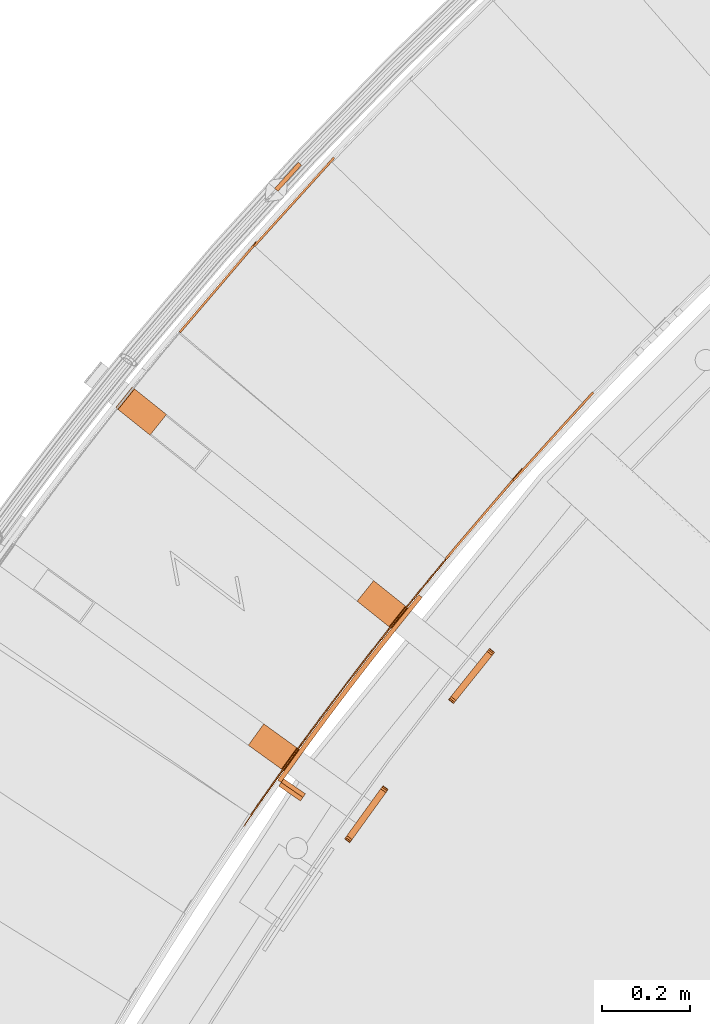
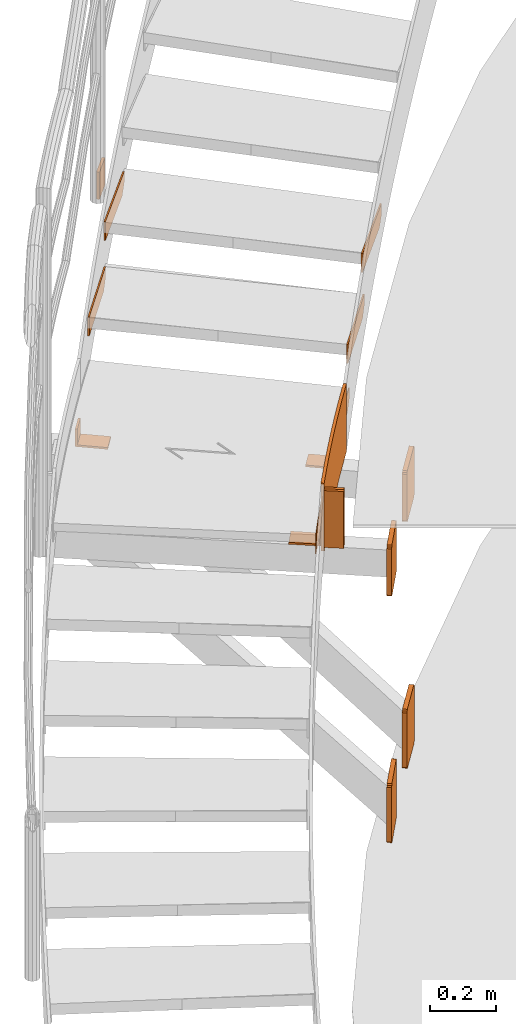
# One storey, part 68 of 126: 16 proxies.
"""IFC2X3 building model written with IfcOpenShell, lengths in millimetres."""

from ifc_helpers import new_model, si_unit, origin, origin_with_axes, place, context, project, spatial, faceted_brep, material, element, save


model = new_model("IFC2X3")

# Units and contexts
context_of_model_1 = context(None, 3, precision=0.1, world=origin())
context_of_model_2 = context(None, 3, precision=0.1, world=origin())
ifc_project = project(units=[si_unit("LENGTHUNIT", "METRE", prefix="MILLI"), si_unit("AREAUNIT", "SQUARE_METRE", prefix="CENTI"), si_unit("VOLUMEUNIT", "CUBIC_METRE", prefix="CENTI"), si_unit("MASSUNIT", "GRAM", prefix="KILO")], contexts=[context_of_model_1, context_of_model_2])

# Site, building, storey
site_placement = place(None, origin_with_axes())
site = spatial("IfcSite", under=ifc_project, at=site_placement, CompositionType="ELEMENT")
building_placement = place(site_placement, origin_with_axes())
building = spatial("IfcBuilding", under=site, at=building_placement, CompositionType="ELEMENT")
storey_placement = place(building_placement, origin_with_axes())
storey = spatial("IfcBuildingStorey", under=building, at=storey_placement, CompositionType="ELEMENT")

# Proxies
ifc_material = material(Name="S235JRG2")
proxy_1_placement = place(storey_placement, origin_with_axes())
element("IfcBuildingElementProxy", 1, at=proxy_1_placement, inside=storey, material=ifc_material, context=context_of_model_2, shape_type="Brep", body=[
    faceted_brep([(1853.9676, 13154.518, 8417.11), (1857.7719, 13151.274, 8417.11), (1857.7719, 13151.274, 8487.11), (1853.9676, 13154.518, 8487.11), (2029.1751, 13359.95, 8487.11), (2032.9794, 13356.706, 8487.11), (2032.9794, 13356.706, 8447.11), (2029.1751, 13359.95, 8447.11), (2009.7076, 13337.125, 8417.11), (2013.5119, 13333.88, 8417.11)], [[[0, 1, 2, 3]], [[4, 5, 6, 7]], [[0, 8, 9, 1]], [[1, 9, 6, 5, 2]], [[2, 5, 4, 3]], [[0, 3, 4, 7, 8]], [[6, 9, 8, 7]]]),
])
proxy_2_placement = place(storey_placement, origin_with_axes())
element("IfcBuildingElementProxy", 2, at=proxy_2_placement, inside=storey, material=ifc_material, context=context_of_model_2, shape_type="Brep", body=[
    faceted_brep([(1249.0844, 13670.407, 8417.11), (1252.8887, 13667.163, 8417.11), (1252.8887, 13667.163, 8487.11), (1249.0844, 13670.407, 8487.11), (1424.292, 13875.839, 8487.11), (1428.0963, 13872.595, 8487.11), (1428.0963, 13872.595, 8447.11), (1424.292, 13875.839, 8447.11), (1404.8245, 13853.013, 8417.11), (1408.6288, 13849.769, 8417.11)], [[[0, 1, 2, 3]], [[4, 5, 6, 7]], [[0, 8, 9, 1]], [[1, 9, 6, 5, 2]], [[2, 5, 4, 3]], [[0, 3, 4, 7, 8]], [[6, 9, 8, 7]]]),
])
proxy_3_placement = place(storey_placement, origin_with_axes())
element("IfcBuildingElementProxy", 3, at=proxy_3_placement, inside=storey, material=ifc_material, context=context_of_model_2, shape_type="Brep", body=[
    faceted_brep([(2008.201, 13333.334, 8590.27), (2011.9082, 13329.979, 8590.27), (2011.9082, 13329.979, 8660.27), (2008.201, 13333.334, 8660.27), (2189.3793, 13533.52, 8660.27), (2193.0864, 13530.165, 8660.27), (2193.0864, 13530.165, 8620.27), (2189.3793, 13533.52, 8620.27), (2169.2483, 13511.277, 8590.27), (2172.9555, 13507.922, 8590.27)], [[[0, 1, 2, 3]], [[4, 5, 6, 7]], [[0, 8, 9, 1]], [[1, 9, 6, 5, 2]], [[2, 5, 4, 3]], [[0, 3, 4, 7, 8]], [[6, 9, 8, 7]]]),
])
proxy_4_placement = place(storey_placement, origin_with_axes())
element("IfcBuildingElementProxy", 4, at=proxy_4_placement, inside=storey, material=ifc_material, context=context_of_model_2, shape_type="Brep", body=[
    faceted_brep([(1418.7644, 13866.803, 8590.27), (1422.4715, 13863.448, 8590.27), (1422.4715, 13863.448, 8660.27), (1418.7644, 13866.803, 8660.27), (1599.9426, 14066.989, 8660.27), (1603.6497, 14063.634, 8660.27), (1603.6497, 14063.634, 8620.27), (1599.9426, 14066.989, 8620.27), (1579.8117, 14044.746, 8590.27), (1583.5188, 14041.391, 8590.27)], [[[0, 1, 2, 3]], [[4, 5, 6, 7]], [[0, 8, 9, 1]], [[1, 9, 6, 5, 2]], [[2, 5, 4, 3]], [[0, 3, 4, 7, 8]], [[6, 9, 8, 7]]]),
])
proxy_5_placement = place(storey_placement, origin_with_axes())
element("IfcBuildingElementProxy", 5, at=proxy_5_placement, inside=storey, material=ifc_material, context=context_of_model_2, shape_type="Brep", body=[
    faceted_brep([(1479.0371, 12658.206, 8163.85), (1487.1793, 12652.4, 8163.85), (1481.7231, 12644.691, 8163.85), (1473.4801, 12650.355, 8163.85), (1487.1793, 12652.4, 8413.85), (1481.7231, 12644.691, 8413.85), (1479.0371, 12658.206, 8413.85), (1473.4801, 12650.355, 8413.85), (1511.6812, 12703.652, 8163.85), (1519.7827, 12697.79, 8163.85), (1519.7827, 12697.79, 8413.85), (1511.6812, 12703.652, 8413.85), (1544.6417, 12748.87, 8163.85), (1552.7021, 12742.951, 8163.85), (1552.7021, 12742.951, 8413.85), (1544.6417, 12748.87, 8413.85), (1577.9169, 12793.856, 8163.85), (1585.9358, 12787.881, 8163.85), (1585.9358, 12787.881, 8413.85), (1577.9169, 12793.856, 8413.85), (1611.5053, 12838.609, 8163.85), (1619.4824, 12832.578, 8163.85), (1619.4824, 12832.578, 8413.85), (1611.5053, 12838.609, 8413.85), (1645.4053, 12883.126, 8163.85), (1653.34, 12877.04, 8163.85), (1653.34, 12877.04, 8413.85), (1645.4053, 12883.126, 8413.85), (1679.6152, 12927.406, 8163.85), (1687.5072, 12921.264, 8163.85), (1687.5072, 12921.264, 8413.85), (1679.6152, 12927.406, 8413.85), (1714.1332, 12971.445, 8163.85), (1721.9822, 12965.249, 8163.85), (1721.9822, 12965.249, 8413.85), (1714.1332, 12971.445, 8413.85), (1748.9578, 13015.243, 8163.85), (1756.7634, 13008.992, 8163.85), (1756.7634, 13008.992, 8413.85), (1748.9578, 13015.243, 8413.85), (1784.0873, 13058.797, 8163.85), (1791.849, 13052.492, 8163.85), (1791.849, 13052.492, 8413.85), (1784.0873, 13058.797, 8413.85), (1794.2648, 13071.236, 8163.85), (1802.5361, 13065.554, 8163.85), (1802.5361, 13065.554, 8413.85), (1794.2648, 13071.236, 8413.85)], [[[0, 1, 2, 3]], [[1, 4, 5, 2]], [[4, 6, 7, 5]], [[0, 3, 7, 6]], [[0, 8, 9, 1]], [[1, 9, 10, 4]], [[4, 10, 11, 6]], [[6, 11, 8, 0]], [[8, 12, 13, 9]], [[9, 13, 14, 10]], [[10, 14, 15, 11]], [[11, 15, 12, 8]], [[12, 16, 17, 13]], [[13, 17, 18, 14]], [[14, 18, 19, 15]], [[15, 19, 16, 12]], [[16, 20, 21, 17]], [[17, 21, 22, 18]], [[18, 22, 23, 19]], [[19, 23, 20, 16]], [[20, 24, 25, 21]], [[21, 25, 26, 22]], [[22, 26, 27, 23]], [[23, 27, 24, 20]], [[24, 28, 29, 25]], [[25, 29, 30, 26]], [[26, 30, 31, 27]], [[27, 31, 28, 24]], [[28, 32, 33, 29]], [[29, 33, 34, 30]], [[30, 34, 35, 31]], [[31, 35, 32, 28]], [[32, 36, 37, 33]], [[33, 37, 38, 34]], [[34, 38, 39, 35]], [[35, 39, 36, 32]], [[36, 40, 41, 37]], [[37, 41, 42, 38]], [[38, 42, 43, 39]], [[39, 43, 40, 36]], [[40, 44, 45, 41]], [[41, 45, 46, 42]], [[42, 46, 47, 43]], [[40, 43, 47, 44]], [[2, 5, 7, 3]], [[44, 47, 46, 45]]]),
])
proxy_6_placement = place(storey_placement, origin_with_axes())
element("IfcBuildingElementProxy", 6, at=proxy_6_placement, inside=storey, material=ifc_material, context=context_of_model_2, shape_type="Brep", body=[
    faceted_brep([(1105.1728, 13497.322, 8228.85), (1142.6996, 13544.138, 8228.85), (1142.6996, 13544.138, 8163.85), (1105.1728, 13497.322, 8163.85), (1110.6347, 13492.944, 8228.85), (1148.1615, 13539.76, 8228.85), (1110.6347, 13492.944, 8170.85), (1148.1615, 13539.76, 8170.85), (1183.1995, 13434.777, 8170.85), (1220.7263, 13481.593, 8170.85), (1183.1995, 13434.777, 8163.85), (1220.7263, 13481.593, 8163.85)], [[[0, 1, 2, 3]], [[0, 4, 5, 1]], [[4, 6, 7, 5]], [[6, 8, 9, 7]], [[8, 10, 11, 9]], [[3, 2, 11, 10]], [[3, 10, 8, 6, 4, 0]], [[1, 5, 7, 9, 11, 2]]]),
])
proxy_7_placement = place(storey_placement, origin_with_axes())
element("IfcBuildingElementProxy", 7, at=proxy_7_placement, inside=storey, material=ifc_material, context=context_of_model_2, shape_type="Brep", body=[
    faceted_brep([(1958.0072, 12929.051, 8018.85), (1961.5974, 12933.53, 8019.9918), (1964.6411, 12937.327, 8023.2434), (1966.6748, 12939.864, 8028.1098), (1967.3889, 12940.755, 8033.85), (1967.3889, 12940.755, 8193.85), (1966.6748, 12939.864, 8199.5903), (1964.6411, 12937.327, 8204.4566), (1961.5974, 12933.53, 8207.7082), (1958.0072, 12929.051, 8208.85), (1882.9536, 12835.419, 8208.85), (1879.3633, 12830.94, 8207.7082), (1876.3197, 12827.143, 8204.4566), (1874.286, 12824.606, 8199.5903), (1873.5719, 12823.715, 8193.85), (1873.5719, 12823.715, 8033.85), (1874.286, 12824.606, 8028.1098), (1876.3197, 12827.143, 8023.2434), (1879.3633, 12830.94, 8019.9918), (1882.9536, 12835.419, 8018.85), (1946.3032, 12938.433, 8018.85), (1871.2496, 12844.801, 8018.85), (1867.6593, 12840.322, 8019.9918), (1864.6157, 12836.525, 8023.2434), (1862.582, 12833.988, 8028.1098), (1861.8679, 12833.097, 8033.85), (1861.8679, 12833.097, 8193.85), (1862.582, 12833.988, 8199.5903), (1864.6157, 12836.525, 8204.4566), (1867.6593, 12840.322, 8207.7082), (1871.2496, 12844.801, 8208.85), (1946.3032, 12938.433, 8208.85), (1949.8934, 12942.912, 8207.7082), (1952.9371, 12946.709, 8204.4566), (1954.9708, 12949.246, 8199.5903), (1955.6849, 12950.137, 8193.85), (1955.6849, 12950.137, 8033.85), (1954.9708, 12949.246, 8028.1098), (1952.9371, 12946.709, 8023.2434), (1949.8934, 12942.912, 8019.9918)], [[[0, 1, 2, 3, 4, 5, 6, 7, 8, 9, 10, 11, 12, 13, 14, 15, 16, 17, 18, 19]], [[20, 21, 22, 23, 24, 25, 26, 27, 28, 29, 30, 31, 32, 33, 34, 35, 36, 37, 38, 39]], [[0, 20, 39, 1]], [[1, 39, 38, 2]], [[2, 38, 37, 3]], [[3, 37, 36, 4]], [[4, 36, 35, 5]], [[5, 35, 34, 6]], [[6, 34, 33, 7]], [[7, 33, 32, 8]], [[8, 32, 31, 9]], [[9, 31, 30, 10]], [[10, 30, 29, 11]], [[11, 29, 28, 12]], [[12, 28, 27, 13]], [[13, 27, 26, 14]], [[14, 26, 25, 15]], [[15, 25, 24, 16]], [[16, 24, 23, 17]], [[17, 23, 22, 18]], [[18, 22, 21, 19]], [[19, 21, 20, 0]]]),
])
proxy_8_placement = place(storey_placement, origin_with_axes())
element("IfcBuildingElementProxy", 8, at=proxy_8_placement, inside=storey, material=ifc_material, context=context_of_model_2, shape_type="Brep", body=[
    faceted_brep([(1958.0073, 12929.051, 7109.1772), (1961.5975, 12933.53, 7110.319), (1964.6411, 12937.327, 7113.5706), (1966.6748, 12939.864, 7118.4369), (1967.389, 12940.755, 7124.1772), (1967.389, 12940.755, 7314.1772), (1966.6748, 12939.864, 7319.9174), (1964.6411, 12937.327, 7324.7838), (1961.5975, 12933.53, 7328.0354), (1958.0073, 12929.051, 7329.1772), (1882.9536, 12835.419, 7329.1772), (1879.3634, 12830.94, 7328.0354), (1876.3198, 12827.143, 7324.7838), (1874.2861, 12824.606, 7319.9174), (1873.5719, 12823.715, 7314.1772), (1873.5719, 12823.715, 7124.1772), (1874.2861, 12824.606, 7118.4369), (1876.3198, 12827.143, 7113.5706), (1879.3634, 12830.94, 7110.319), (1882.9536, 12835.419, 7109.1772), (1946.3033, 12938.433, 7109.1772), (1871.2496, 12844.801, 7109.1772), (1867.6594, 12840.322, 7110.319), (1864.6158, 12836.525, 7113.5706), (1862.5821, 12833.988, 7118.4369), (1861.8679, 12833.097, 7124.1772), (1861.8679, 12833.097, 7314.1772), (1862.5821, 12833.988, 7319.9174), (1864.6158, 12836.525, 7324.7838), (1867.6594, 12840.322, 7328.0354), (1871.2496, 12844.801, 7329.1772), (1946.3033, 12938.433, 7329.1772), (1949.8935, 12942.912, 7328.0354), (1952.9371, 12946.709, 7324.7838), (1954.9708, 12949.246, 7319.9174), (1955.685, 12950.137, 7314.1772), (1955.685, 12950.137, 7124.1772), (1954.9708, 12949.246, 7118.4369), (1952.9371, 12946.709, 7113.5706), (1949.8935, 12942.912, 7110.319)], [[[0, 1, 2, 3, 4, 5, 6, 7, 8, 9, 10, 11, 12, 13, 14, 15, 16, 17, 18, 19]], [[20, 21, 22, 23, 24, 25, 26, 27, 28, 29, 30, 31, 32, 33, 34, 35, 36, 37, 38, 39]], [[0, 20, 39, 1]], [[1, 39, 38, 2]], [[2, 38, 37, 3]], [[3, 37, 36, 4]], [[4, 36, 35, 5]], [[5, 35, 34, 6]], [[6, 34, 33, 7]], [[7, 33, 32, 8]], [[8, 32, 31, 9]], [[9, 31, 30, 10]], [[10, 30, 29, 11]], [[11, 29, 28, 12]], [[12, 28, 27, 13]], [[13, 27, 26, 14]], [[14, 26, 25, 15]], [[15, 25, 24, 16]], [[16, 24, 23, 17]], [[17, 23, 22, 18]], [[18, 22, 21, 19]], [[19, 21, 20, 0]]]),
])
proxy_9_placement = place(storey_placement, origin_with_axes())
element("IfcBuildingElementProxy", 9, at=proxy_9_placement, inside=storey, material=ifc_material, context=context_of_model_2, shape_type="Brep", body=[
    faceted_brep([(1394.7133, 12546.422, 8243.85), (1397.1859, 12544.723, 8243.85), (1397.1859, 12544.723, 8313.85), (1394.7133, 12546.422, 8313.85), (1399.1426, 12552.869, 8243.85), (1401.6136, 12551.167, 8243.85), (1401.6136, 12551.167, 8313.85), (1399.1426, 12552.869, 8313.85), (1408.0263, 12565.745, 8243.85), (1410.494, 12564.039, 8243.85), (1410.494, 12564.039, 8313.85), (1408.0263, 12565.745, 8313.85), (1416.9351, 12578.604, 8243.85), (1419.3994, 12576.893, 8243.85), (1419.3994, 12576.893, 8313.85), (1416.9351, 12578.604, 8313.85), (1425.869, 12591.446, 8243.85), (1428.33, 12589.73, 8243.85), (1428.33, 12589.73, 8313.85), (1425.869, 12591.446, 8313.85), (1434.8279, 12604.27, 8243.85), (1437.2855, 12602.55, 8243.85), (1437.2855, 12602.55, 8313.85), (1434.8279, 12604.27, 8313.85), (1443.8118, 12617.077, 8243.85), (1446.2661, 12615.352, 8243.85), (1446.2661, 12615.352, 8313.85), (1443.8118, 12617.077, 8313.85), (1452.8207, 12629.866, 8243.85), (1455.2716, 12628.136, 8243.85), (1455.2716, 12628.136, 8313.85), (1452.8207, 12629.866, 8313.85), (1461.8545, 12642.638, 8243.85), (1464.302, 12640.903, 8243.85), (1464.302, 12640.903, 8313.85), (1461.8545, 12642.638, 8313.85), (1470.9131, 12655.392, 8243.85), (1473.3573, 12653.653, 8243.85), (1473.3573, 12653.653, 8313.85), (1470.9131, 12655.392, 8313.85), (1479.9967, 12668.129, 8243.85), (1482.4375, 12666.384, 8243.85), (1482.4375, 12666.384, 8313.85), (1479.9967, 12668.129, 8313.85), (1489.1051, 12680.847, 8243.85), (1491.5424, 12679.098, 8243.85), (1491.5424, 12679.098, 8313.85), (1489.1051, 12680.847, 8313.85), (1498.2383, 12693.548, 8243.85), (1500.6722, 12691.794, 8243.85), (1500.6722, 12691.794, 8313.85), (1498.2383, 12693.548, 8313.85), (1507.3962, 12706.231, 8243.85), (1509.8267, 12704.472, 8243.85), (1509.8267, 12704.472, 8313.85), (1507.3962, 12706.231, 8313.85), (1516.5788, 12718.896, 8243.85), (1519.0059, 12717.133, 8243.85), (1519.0059, 12717.133, 8313.85), (1516.5788, 12718.896, 8313.85), (1525.7862, 12731.543, 8243.85), (1528.2098, 12729.775, 8243.85), (1528.2098, 12729.775, 8313.85), (1525.7862, 12731.543, 8313.85), (1535.0182, 12744.172, 8243.85), (1537.4383, 12742.4, 8243.85), (1537.4383, 12742.4, 8313.85), (1535.0182, 12744.172, 8313.85), (1544.2748, 12756.783, 8243.85), (1546.6915, 12755.006, 8243.85), (1546.6915, 12755.006, 8313.85), (1544.2748, 12756.783, 8313.85), (1553.556, 12769.377, 8243.85), (1555.9692, 12767.594, 8243.85), (1555.9692, 12767.594, 8313.85), (1553.556, 12769.377, 8313.85), (1562.8617, 12781.951, 8243.85), (1565.2715, 12780.165, 8243.85), (1565.2715, 12780.165, 8313.85), (1562.8617, 12781.951, 8313.85), (1572.1919, 12794.508, 8243.85), (1574.5982, 12792.717, 8243.85), (1574.5982, 12792.717, 8313.85), (1572.1919, 12794.508, 8313.85), (1581.5467, 12807.047, 8243.85), (1583.9494, 12805.25, 8243.85), (1583.9494, 12805.25, 8313.85), (1581.5467, 12807.047, 8313.85), (1590.9258, 12819.567, 8243.85), (1593.3251, 12817.766, 8243.85), (1593.3251, 12817.766, 8313.85), (1590.9258, 12819.567, 8313.85), (1600.3294, 12832.069, 8243.85), (1602.7251, 12830.263, 8243.85), (1602.7251, 12830.263, 8313.85), (1600.3294, 12832.069, 8313.85), (1609.7573, 12844.552, 8243.85), (1612.1495, 12842.742, 8243.85), (1612.1495, 12842.742, 8313.85), (1609.7573, 12844.552, 8313.85), (1619.2096, 12857.018, 8243.85), (1621.5983, 12855.203, 8243.85), (1621.5983, 12855.203, 8313.85), (1619.2096, 12857.018, 8313.85), (1628.6861, 12869.464, 8243.85), (1631.0713, 12867.645, 8243.85), (1631.0713, 12867.645, 8313.85), (1628.6861, 12869.464, 8313.85), (1638.187, 12881.893, 8243.85), (1640.5686, 12880.068, 8243.85), (1640.5686, 12880.068, 8313.85), (1638.187, 12881.893, 8313.85), (1647.712, 12894.302, 8243.85), (1650.09, 12892.473, 8243.85), (1650.09, 12892.473, 8313.85), (1647.712, 12894.302, 8313.85), (1657.2613, 12906.693, 8243.85), (1659.6357, 12904.86, 8243.85), (1659.6357, 12904.86, 8313.85), (1657.2613, 12906.693, 8313.85), (1666.8346, 12919.066, 8243.85), (1669.2055, 12917.227, 8243.85), (1669.2055, 12917.227, 8313.85), (1666.8346, 12919.066, 8313.85), (1676.4321, 12931.419, 8243.85), (1678.7994, 12929.576, 8243.85), (1678.7994, 12929.576, 8313.85), (1676.4321, 12931.419, 8313.85), (1686.0537, 12943.754, 8243.85), (1688.4174, 12941.907, 8243.85), (1688.4174, 12941.907, 8313.85), (1686.0537, 12943.754, 8313.85), (1695.6993, 12956.07, 8243.85), (1698.0594, 12954.218, 8243.85), (1698.0594, 12954.218, 8313.85), (1695.6993, 12956.07, 8313.85), (1705.369, 12968.368, 8243.85), (1707.7254, 12966.511, 8243.85), (1707.7254, 12966.511, 8313.85), (1705.369, 12968.368, 8313.85), (1715.0626, 12980.646, 8243.85), (1717.4154, 12978.785, 8243.85), (1717.4154, 12978.785, 8313.85), (1715.0626, 12980.646, 8313.85), (1724.7801, 12992.906, 8243.85), (1727.1293, 12991.04, 8243.85), (1727.1293, 12991.04, 8313.85), (1724.7801, 12992.906, 8313.85), (1734.5215, 13005.146, 8243.85), (1736.8671, 13003.276, 8243.85), (1736.8671, 13003.276, 8313.85), (1734.5215, 13005.146, 8313.85), (1744.2868, 13017.368, 8243.85), (1746.6287, 13015.493, 8243.85), (1746.6287, 13015.493, 8313.85), (1744.2868, 13017.368, 8313.85), (1754.0759, 13029.57, 8243.85), (1756.4141, 13027.69, 8243.85), (1756.4141, 13027.69, 8313.85), (1754.0759, 13029.57, 8313.85), (1763.8888, 13041.753, 8243.85), (1766.2233, 13039.869, 8243.85), (1766.2233, 13039.869, 8313.85), (1763.8888, 13041.753, 8313.85), (1773.7254, 13053.917, 8243.85), (1776.0563, 13052.029, 8243.85), (1776.0563, 13052.029, 8313.85), (1773.7254, 13053.917, 8313.85), (1783.5857, 13066.062, 8243.85), (1785.9129, 13064.169, 8243.85), (1785.9129, 13064.169, 8313.85), (1783.5857, 13066.062, 8313.85), (1793.4697, 13078.188, 8243.85), (1795.7932, 13076.29, 8243.85), (1795.7932, 13076.29, 8313.85), (1793.4697, 13078.188, 8313.85), (1803.3774, 13090.294, 8243.85), (1805.6972, 13088.392, 8243.85), (1805.6972, 13088.392, 8313.85), (1803.3774, 13090.294, 8313.85), (1813.3086, 13102.381, 8243.85), (1815.6247, 13100.475, 8243.85), (1815.6247, 13100.475, 8313.85), (1813.3086, 13102.381, 8313.85), (1823.2634, 13114.449, 8243.85), (1825.5758, 13112.538, 8243.85), (1825.5758, 13112.538, 8313.85), (1823.2634, 13114.449, 8313.85), (1833.2417, 13126.497, 8243.85), (1835.5503, 13124.581, 8243.85), (1835.5503, 13124.581, 8313.85), (1833.2417, 13126.497, 8313.85), (1843.2435, 13138.526, 8243.85), (1845.5484, 13136.606, 8243.85), (1845.5484, 13136.606, 8313.85), (1843.2435, 13138.526, 8313.85), (1848.9929, 13145.413, 8243.85), (1851.4764, 13143.707, 8243.85), (1855.5699, 13148.61, 8250.2096), (1855.5699, 13148.61, 8313.85), (1853.2688, 13150.535, 8313.85), (1853.2688, 13150.535, 8250.493), (1865.6148, 13160.595, 8265.7761), (1865.6148, 13160.595, 8313.85), (1863.3174, 13162.525, 8313.85), (1863.3174, 13162.525, 8266.0653), (1870.6489, 13166.578, 8273.5579), (1870.6489, 13166.578, 8313.85), (1868.3534, 13168.51, 8313.85), (1868.3534, 13168.51, 8273.85)], [[[0, 1, 2, 3]], [[0, 4, 5, 1]], [[1, 5, 6, 2]], [[2, 6, 7, 3]], [[3, 7, 4, 0]], [[4, 8, 9, 5]], [[5, 9, 10, 6]], [[6, 10, 11, 7]], [[7, 11, 8, 4]], [[8, 12, 13, 9]], [[9, 13, 14, 10]], [[10, 14, 15, 11]], [[11, 15, 12, 8]], [[12, 16, 17, 13]], [[13, 17, 18, 14]], [[14, 18, 19, 15]], [[15, 19, 16, 12]], [[16, 20, 21, 17]], [[17, 21, 22, 18]], [[18, 22, 23, 19]], [[19, 23, 20, 16]], [[20, 24, 25, 21]], [[21, 25, 26, 22]], [[22, 26, 27, 23]], [[23, 27, 24, 20]], [[24, 28, 29, 25]], [[25, 29, 30, 26]], [[26, 30, 31, 27]], [[27, 31, 28, 24]], [[28, 32, 33, 29]], [[29, 33, 34, 30]], [[30, 34, 35, 31]], [[31, 35, 32, 28]], [[32, 36, 37, 33]], [[33, 37, 38, 34]], [[34, 38, 39, 35]], [[35, 39, 36, 32]], [[36, 40, 41, 37]], [[37, 41, 42, 38]], [[38, 42, 43, 39]], [[39, 43, 40, 36]], [[40, 44, 45, 41]], [[41, 45, 46, 42]], [[42, 46, 47, 43]], [[43, 47, 44, 40]], [[44, 48, 49, 45]], [[45, 49, 50, 46]], [[46, 50, 51, 47]], [[47, 51, 48, 44]], [[48, 52, 53, 49]], [[49, 53, 54, 50]], [[50, 54, 55, 51]], [[51, 55, 52, 48]], [[52, 56, 57, 53]], [[53, 57, 58, 54]], [[54, 58, 59, 55]], [[55, 59, 56, 52]], [[56, 60, 61, 57]], [[57, 61, 62, 58]], [[58, 62, 63, 59]], [[59, 63, 60, 56]], [[60, 64, 65, 61]], [[61, 65, 66, 62]], [[62, 66, 67, 63]], [[63, 67, 64, 60]], [[64, 68, 69, 65]], [[65, 69, 70, 66]], [[66, 70, 71, 67]], [[67, 71, 68, 64]], [[68, 72, 73, 69]], [[69, 73, 74, 70]], [[70, 74, 75, 71]], [[71, 75, 72, 68]], [[72, 76, 77, 73]], [[73, 77, 78, 74]], [[74, 78, 79, 75]], [[75, 79, 76, 72]], [[76, 80, 81, 77]], [[77, 81, 82, 78]], [[78, 82, 83, 79]], [[79, 83, 80, 76]], [[80, 84, 85, 81]], [[81, 85, 86, 82]], [[82, 86, 87, 83]], [[83, 87, 84, 80]], [[84, 88, 89, 85]], [[85, 89, 90, 86]], [[86, 90, 91, 87]], [[87, 91, 88, 84]], [[88, 92, 93, 89]], [[89, 93, 94, 90]], [[90, 94, 95, 91]], [[91, 95, 92, 88]], [[92, 96, 97, 93]], [[93, 97, 98, 94]], [[94, 98, 99, 95]], [[95, 99, 96, 92]], [[96, 100, 101, 97]], [[97, 101, 102, 98]], [[98, 102, 103, 99]], [[99, 103, 100, 96]], [[100, 104, 105, 101]], [[101, 105, 106, 102]], [[102, 106, 107, 103]], [[103, 107, 104, 100]], [[104, 108, 109, 105]], [[105, 109, 110, 106]], [[106, 110, 111, 107]], [[107, 111, 108, 104]], [[108, 112, 113, 109]], [[109, 113, 114, 110]], [[110, 114, 115, 111]], [[111, 115, 112, 108]], [[112, 116, 117, 113]], [[113, 117, 118, 114]], [[114, 118, 119, 115]], [[115, 119, 116, 112]], [[116, 120, 121, 117]], [[117, 121, 122, 118]], [[118, 122, 123, 119]], [[119, 123, 120, 116]], [[120, 124, 125, 121]], [[121, 125, 126, 122]], [[122, 126, 127, 123]], [[123, 127, 124, 120]], [[124, 128, 129, 125]], [[125, 129, 130, 126]], [[126, 130, 131, 127]], [[127, 131, 128, 124]], [[128, 132, 133, 129]], [[129, 133, 134, 130]], [[130, 134, 135, 131]], [[131, 135, 132, 128]], [[132, 136, 137, 133]], [[133, 137, 138, 134]], [[134, 138, 139, 135]], [[135, 139, 136, 132]], [[136, 140, 141, 137]], [[137, 141, 142, 138]], [[138, 142, 143, 139]], [[139, 143, 140, 136]], [[140, 144, 145, 141]], [[141, 145, 146, 142]], [[142, 146, 147, 143]], [[143, 147, 144, 140]], [[144, 148, 149, 145]], [[145, 149, 150, 146]], [[146, 150, 151, 147]], [[147, 151, 148, 144]], [[148, 152, 153, 149]], [[149, 153, 154, 150]], [[150, 154, 155, 151]], [[151, 155, 152, 148]], [[152, 156, 157, 153]], [[153, 157, 158, 154]], [[154, 158, 159, 155]], [[155, 159, 156, 152]], [[156, 160, 161, 157]], [[157, 161, 162, 158]], [[158, 162, 163, 159]], [[159, 163, 160, 156]], [[160, 164, 165, 161]], [[161, 165, 166, 162]], [[162, 166, 167, 163]], [[163, 167, 164, 160]], [[164, 168, 169, 165]], [[165, 169, 170, 166]], [[166, 170, 171, 167]], [[167, 171, 168, 164]], [[168, 172, 173, 169]], [[169, 173, 174, 170]], [[170, 174, 175, 171]], [[171, 175, 172, 168]], [[172, 176, 177, 173]], [[173, 177, 178, 174]], [[174, 178, 179, 175]], [[175, 179, 176, 172]], [[176, 180, 181, 177]], [[177, 181, 182, 178]], [[178, 182, 183, 179]], [[179, 183, 180, 176]], [[180, 184, 185, 181]], [[181, 185, 186, 182]], [[182, 186, 187, 183]], [[183, 187, 184, 180]], [[184, 188, 189, 185]], [[185, 189, 190, 186]], [[186, 190, 191, 187]], [[187, 191, 188, 184]], [[188, 192, 193, 189]], [[189, 193, 194, 190]], [[190, 194, 195, 191]], [[191, 195, 192, 188]], [[192, 196, 197, 193]], [[193, 197, 198, 199, 194]], [[194, 199, 200, 195]], [[192, 195, 200, 201, 196]], [[198, 202, 203, 199]], [[199, 203, 204, 200]], [[200, 204, 205, 201]], [[203, 202, 206, 207]], [[203, 207, 208, 204]], [[204, 208, 209, 205]], [[207, 206, 209, 208]], [[196, 201, 205, 209, 206, 202, 198, 197]]]),
])
proxy_10_placement = place(storey_placement, origin_with_axes())
element("IfcBuildingElementProxy", 10, at=proxy_10_placement, inside=storey, material=ifc_material, context=context_of_model_2, shape_type="Brep", body=[
    faceted_brep([(1487.9865, 12670.817, 8228.85), (1487.9865, 12670.817, 8163.85), (1523.0967, 12719.472, 8163.85), (1523.0967, 12719.472, 8228.85), (1517.4204, 12723.568, 8228.85), (1482.3102, 12674.913, 8228.85), (1517.4204, 12723.568, 8170.85), (1482.3102, 12674.913, 8170.85), (1442.0057, 12777.989, 8170.85), (1406.8955, 12729.334, 8170.85), (1442.0057, 12777.989, 8163.85), (1406.8955, 12729.334, 8163.85)], [[[0, 1, 2, 3]], [[0, 3, 4, 5]], [[5, 4, 6, 7]], [[7, 6, 8, 9]], [[9, 8, 10, 11]], [[1, 11, 10, 2]], [[1, 0, 5, 7, 9, 11]], [[3, 2, 10, 8, 6, 4]]]),
])
proxy_11_placement = place(storey_placement, origin_with_axes())
element("IfcBuildingElementProxy", 11, at=proxy_11_placement, inside=storey, material=ifc_material, context=context_of_model_2, shape_type="Brep", body=[
    faceted_brep([(1732.3899, 12994.557, 8228.85), (1732.3899, 12994.557, 8163.85), (1769.9167, 13041.373, 8163.85), (1769.9167, 13041.373, 8228.85), (1764.4548, 13045.751, 8228.85), (1726.928, 12998.935, 8228.85), (1764.4548, 13045.751, 8170.85), (1726.928, 12998.935, 8170.85), (1691.89, 13103.917, 8170.85), (1654.3632, 13057.101, 8170.85), (1691.89, 13103.917, 8163.85), (1654.3632, 13057.101, 8163.85)], [[[0, 1, 2, 3]], [[0, 3, 4, 5]], [[5, 4, 6, 7]], [[7, 6, 8, 9]], [[9, 8, 10, 11]], [[1, 11, 10, 2]], [[1, 0, 5, 7, 9, 11]], [[3, 2, 10, 8, 6, 4]]]),
])
proxy_12_placement = place(storey_placement, origin_with_axes())
element("IfcBuildingElementProxy", 12, at=proxy_12_placement, inside=storey, material=ifc_material, context=context_of_model_2, shape_type="Brep", body=[
    faceted_brep([(1716.629, 12616.81, 8018.85), (1719.988, 12621.465, 8019.9918), (1722.8357, 12625.411, 8023.2434), (1724.7384, 12628.048, 8028.1098), (1725.4066, 12628.974, 8033.85), (1725.4066, 12628.974, 8193.85), (1724.7384, 12628.048, 8199.5903), (1722.8357, 12625.411, 8204.4566), (1719.988, 12621.465, 8207.7082), (1716.629, 12616.81, 8208.85), (1646.4086, 12519.501, 8208.85), (1643.0496, 12514.846, 8207.7082), (1640.2019, 12510.9, 8204.4566), (1638.2992, 12508.263, 8199.5903), (1637.6311, 12507.337, 8193.85), (1637.6311, 12507.337, 8033.85), (1638.2992, 12508.263, 8028.1098), (1640.2019, 12510.9, 8023.2434), (1643.0496, 12514.846, 8019.9918), (1646.4086, 12519.501, 8018.85), (1704.4653, 12625.588, 8018.85), (1634.245, 12528.279, 8018.85), (1630.8859, 12523.624, 8019.9918), (1628.0383, 12519.678, 8023.2434), (1626.1356, 12517.041, 8028.1098), (1625.4674, 12516.115, 8033.85), (1625.4674, 12516.115, 8193.85), (1626.1356, 12517.041, 8199.5903), (1628.0383, 12519.678, 8204.4566), (1630.8859, 12523.624, 8207.7082), (1634.245, 12528.279, 8208.85), (1704.4653, 12625.588, 8208.85), (1707.8244, 12630.243, 8207.7082), (1710.672, 12634.189, 8204.4566), (1712.5747, 12636.826, 8199.5903), (1713.2429, 12637.751, 8193.85), (1713.2429, 12637.751, 8033.85), (1712.5747, 12636.826, 8028.1098), (1710.672, 12634.189, 8023.2434), (1707.8244, 12630.243, 8019.9918)], [[[0, 1, 2, 3, 4, 5, 6, 7, 8, 9, 10, 11, 12, 13, 14, 15, 16, 17, 18, 19]], [[20, 21, 22, 23, 24, 25, 26, 27, 28, 29, 30, 31, 32, 33, 34, 35, 36, 37, 38, 39]], [[0, 20, 39, 1]], [[1, 39, 38, 2]], [[2, 38, 37, 3]], [[3, 37, 36, 4]], [[4, 36, 35, 5]], [[5, 35, 34, 6]], [[6, 34, 33, 7]], [[7, 33, 32, 8]], [[8, 32, 31, 9]], [[9, 31, 30, 10]], [[10, 30, 29, 11]], [[11, 29, 28, 12]], [[12, 28, 27, 13]], [[13, 27, 26, 14]], [[14, 26, 25, 15]], [[15, 25, 24, 16]], [[16, 24, 23, 17]], [[17, 23, 22, 18]], [[18, 22, 21, 19]], [[19, 21, 20, 0]]]),
])
proxy_13_placement = place(storey_placement, origin_with_axes())
element("IfcBuildingElementProxy", 13, at=proxy_13_placement, inside=storey, material=ifc_material, context=context_of_model_2, shape_type="Brep", body=[
    faceted_brep([(1716.6291, 12616.81, 7109.1772), (1719.9881, 12621.465, 7110.319), (1722.8358, 12625.411, 7113.5706), (1724.7385, 12628.048, 7118.4369), (1725.4066, 12628.974, 7124.1772), (1725.4066, 12628.974, 7314.1772), (1724.7385, 12628.048, 7319.9174), (1722.8358, 12625.411, 7324.7838), (1719.9881, 12621.465, 7328.0354), (1716.6291, 12616.81, 7329.1772), (1646.4087, 12519.501, 7329.1772), (1643.0497, 12514.846, 7328.0354), (1640.202, 12510.9, 7324.7838), (1638.2993, 12508.263, 7319.9174), (1637.6311, 12507.337, 7314.1772), (1637.6311, 12507.337, 7124.1772), (1638.2993, 12508.263, 7118.4369), (1640.202, 12510.9, 7113.5706), (1643.0497, 12514.846, 7110.319), (1646.4087, 12519.501, 7109.1772), (1704.4654, 12625.588, 7109.1772), (1634.245, 12528.278, 7109.1772), (1630.886, 12523.624, 7110.319), (1628.0384, 12519.677, 7113.5706), (1626.1356, 12517.041, 7118.4369), (1625.4675, 12516.115, 7124.1772), (1625.4675, 12516.115, 7314.1772), (1626.1356, 12517.041, 7319.9174), (1628.0384, 12519.677, 7324.7838), (1630.886, 12523.624, 7328.0354), (1634.245, 12528.278, 7329.1772), (1704.4654, 12625.588, 7329.1772), (1707.8245, 12630.243, 7328.0354), (1710.6721, 12634.189, 7324.7838), (1712.5748, 12636.825, 7319.9174), (1713.243, 12637.751, 7314.1772), (1713.243, 12637.751, 7124.1772), (1712.5748, 12636.825, 7118.4369), (1710.6721, 12634.189, 7113.5706), (1707.8245, 12630.243, 7110.319)], [[[0, 1, 2, 3, 4, 5, 6, 7, 8, 9, 10, 11, 12, 13, 14, 15, 16, 17, 18, 19]], [[20, 21, 22, 23, 24, 25, 26, 27, 28, 29, 30, 31, 32, 33, 34, 35, 36, 37, 38, 39]], [[0, 20, 39, 1]], [[1, 39, 38, 2]], [[2, 38, 37, 3]], [[3, 37, 36, 4]], [[4, 36, 35, 5]], [[5, 35, 34, 6]], [[6, 34, 33, 7]], [[7, 33, 32, 8]], [[8, 32, 31, 9]], [[9, 31, 30, 10]], [[10, 30, 29, 11]], [[11, 29, 28, 12]], [[12, 28, 27, 13]], [[13, 27, 26, 14]], [[14, 26, 25, 15]], [[15, 25, 24, 16]], [[16, 24, 23, 17]], [[17, 23, 22, 18]], [[18, 22, 21, 19]], [[19, 21, 20, 0]]]),
])
proxy_14_placement = place(storey_placement, origin_with_axes())
element("IfcBuildingElementProxy", 14, at=proxy_14_placement, inside=storey, material=ifc_material, context=context_of_model_2, shape_type="Brep", body=[
    faceted_brep([(1481.723, 12644.691, 8393.85), (1487.3856, 12652.933, 8393.85), (1487.3856, 12652.933, 8183.85), (1481.723, 12644.691, 8183.85), (1536.8391, 12618.958, 8393.85), (1531.1765, 12610.716, 8393.85), (1531.1765, 12610.716, 8183.85), (1536.8391, 12618.958, 8183.85)], [[[0, 1, 2, 3]], [[4, 5, 6, 7]], [[0, 3, 6, 5]], [[1, 4, 7, 2]], [[0, 5, 4, 1]], [[2, 7, 6, 3]]]),
])
proxy_15_placement = place(storey_placement, origin_with_axes())
element("IfcBuildingElementProxy", 15, at=proxy_15_placement, inside=storey, material=ifc_material, context=context_of_model_2, shape_type="Brep", body=[
    faceted_brep([(1476.0604, 12636.449, 8393.85), (1481.723, 12644.691, 8393.85), (1481.723, 12644.691, 8183.85), (1476.0604, 12636.449, 8183.85), (1531.1765, 12610.716, 8393.85), (1525.5139, 12602.473, 8393.85), (1525.5139, 12602.473, 8183.85), (1531.1765, 12610.716, 8183.85)], [[[0, 1, 2, 3]], [[4, 5, 6, 7]], [[0, 3, 6, 5]], [[1, 4, 7, 2]], [[0, 5, 4, 1]], [[2, 7, 6, 3]]]),
])
proxy_16_placement = place(storey_placement, origin_with_axes())
element("IfcBuildingElementProxy", 16, at=proxy_16_placement, inside=storey, material=ifc_material, Name="HANDLAUF", context=context_of_model_2, shape_type="Brep", body=[
    faceted_brep([(1520.4512, 14055.343, 8647.7049), (1527.8668, 14048.634, 8647.7049), (1474.1958, 13989.309, 8647.7049), (1466.7802, 13996.018, 8647.7049), (1520.4512, 14055.343, 8747.7049), (1466.7802, 13996.018, 8747.7049), (1474.1958, 13989.309, 8747.7049), (1527.8668, 14048.634, 8747.7049)], [[[0, 1, 2, 3]], [[4, 5, 6, 7]], [[0, 4, 7, 1]], [[1, 7, 6, 2]], [[2, 6, 5, 3]], [[3, 5, 4, 0]]]),
])

save(model, "model.ifc")
